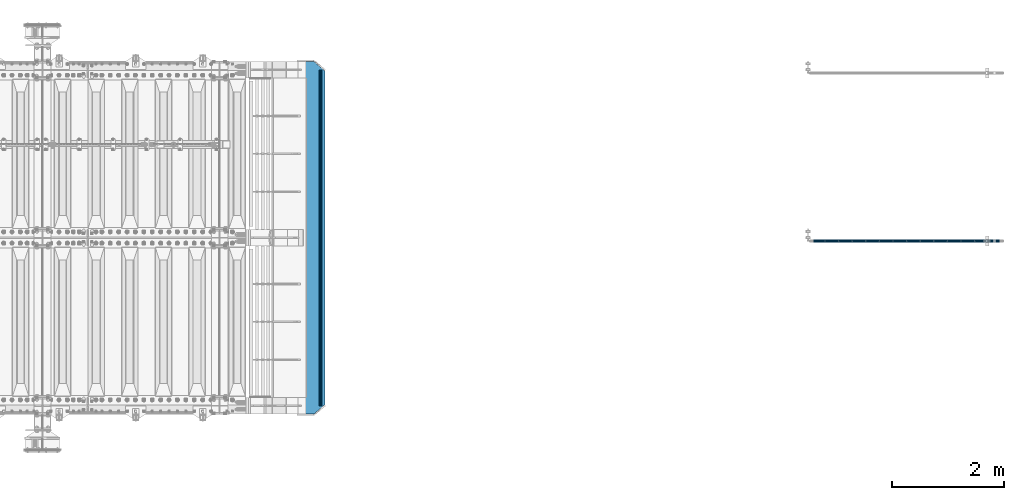
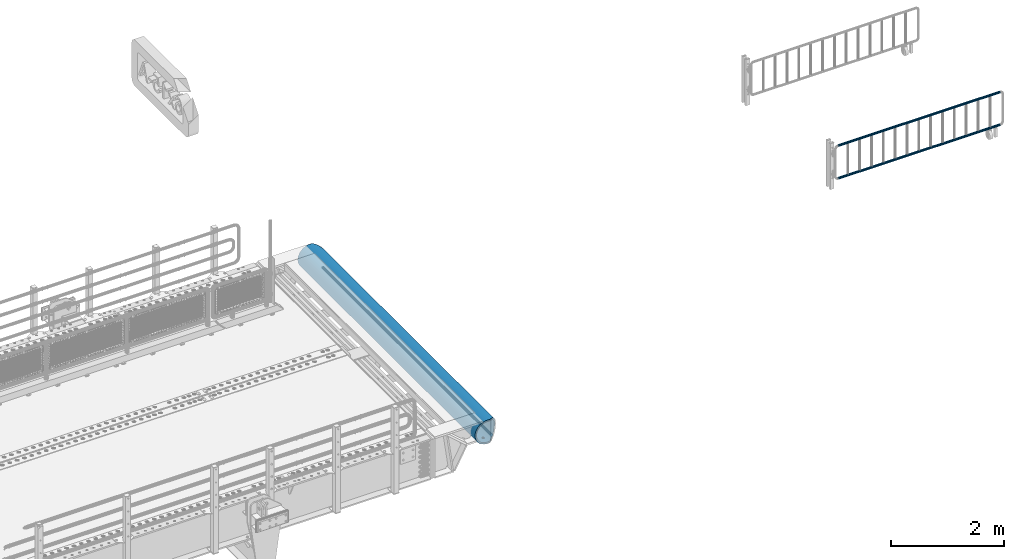
# One storey, part 103 of 193: 4 beams.
"""IFC2X3 building model written with IfcOpenShell, lengths in millimetres."""

from ifc_helpers import new_model, si_unit, frame, origin_with_axes, place, context, subcontext, project, spatial, faceted_brep, material, type_object, element, save


model = new_model("IFC2X3")

# Units and contexts
model_context = context("Model", 3, precision=1e-05, world=origin_with_axes())
body_context = subcontext(model_context, "Body", "Model", "MODEL_VIEW")
ifc_project = project(units=[si_unit("LENGTHUNIT", "METRE", prefix="MILLI"), si_unit("AREAUNIT", "SQUARE_METRE"), si_unit("VOLUMEUNIT", "CUBIC_METRE"), si_unit("MASSUNIT", "GRAM", prefix="KILO"), si_unit("TIMEUNIT", "SECOND"), si_unit("PLANEANGLEUNIT", "RADIAN"), si_unit("SOLIDANGLEUNIT", "STERADIAN"), si_unit("THERMODYNAMICTEMPERATUREUNIT", "DEGREE_CELSIUS"), si_unit("LUMINOUSINTENSITYUNIT", "LUMEN")], contexts=[model_context])

# Site, building, storey
site_placement = place(None, origin_with_axes())
site = spatial("IfcSite", under=ifc_project, at=site_placement, CompositionType="ELEMENT")
building_placement = place(site_placement, origin_with_axes())
building = spatial("IfcBuilding", under=site, at=building_placement, Name="Standard", CompositionType="ELEMENT")
storey_placement = place(building_placement, origin_with_axes())
storey = spatial("IfcBuildingStorey", under=building, at=storey_placement, Name="Undefined", CompositionType="ELEMENT", Elevation=0.0)

# Beams
ifc_material_1 = material()
beam_type_1 = type_object("IfcBeamType", PredefinedType="NOTDEFINED")
beam_1_placement = place(storey_placement, frame((-18284.7539827644, 26941.8539999962, 935.350006544462), z_axis=(0.0, 0.0, 1.0), x_axis=(1.0, 0.0, 0.0)))
element("IfcBeam", 1, at=beam_1_placement, inside=storey, type_object=beam_type_1, material=ifc_material_1, context=body_context, shape_type="Brep", body=[
    faceted_brep([(0.0, -20.5499999999993, 0.0), (0.0, -17.7968220477705, 10.2750000000015), (3317.7, -17.7968220477705, 10.275), (3317.7, -20.5499999999993, 0.0), (0.0, -10.2750000000015, 17.7968220477705), (3317.7, -10.2750000000015, 17.7968220477702), (0.0, 0.0, 20.5499999999993), (3317.7, 0.0, 20.55), (0.0, 10.2750000000015, 17.7968220477705), (3317.7, 10.2750000000015, 17.7968220477702), (0.0, 17.7968220477705, 10.2750000000015), (3317.7, 17.7968220477705, 10.275), (0.0, 20.5499999999993, 0.0), (3317.7, 20.5499999999993, 0.0), (0.0, 17.7968220477705, -10.2750000000015), (3317.7, 17.7968220477705, -10.275), (0.0, 10.2750000000015, -17.7968220477705), (3317.7, 10.2750000000015, -17.7968220477702), (0.0, 0.0, -20.5499999999993), (3317.7, 0.0, -20.55), (0.0, -10.2750000000015, -17.7968220477705), (3317.7, -10.2750000000015, -17.7968220477702), (0.0, -17.7968220477705, -10.2750000000015), (3317.7, -17.7968220477705, -10.275), (0.0, -24.1500000000015, 0.0), (0.0, -20.9145135013932, -12.0750000000007), (3317.7, -20.9145135013932, -12.075), (3317.7, -24.1500000000015, 0.0), (0.0, -12.0750000000007, -20.9145135013932), (3317.7, -12.0750000000007, -20.9145135013943), (0.0, 0.0, -24.1500000000015), (3317.7, 0.0, -24.15), (0.0, 12.0750000000007, -20.9145135013932), (3317.7, 12.0750000000007, -20.9145135013941), (0.0, 20.9145135013932, -12.0750000000007), (3317.7, 20.9145135013932, -12.075), (0.0, 24.1500000000015, 0.0), (3317.7, 24.1500000000015, 0.0), (0.0, 20.9145135013932, 12.0750000000007), (3317.7, 20.9145135013932, 12.075), (0.0, 12.0750000000007, 20.9145135013932), (3317.7, 12.0750000000007, 20.9145135013941), (0.0, 0.0, 24.1500000000015), (3317.7, 0.0, 24.15), (0.0, -12.0750000000007, 20.9145135013932), (3317.7, -12.0750000000007, 20.9145135013941), (0.0, -20.9145135013932, 12.0750000000007), (3317.7, -20.9145135013932, 12.075)], [[[0, 1, 2, 3]], [[1, 4, 5, 2]], [[4, 6, 7, 5]], [[6, 8, 9, 7]], [[8, 10, 11, 9]], [[10, 12, 13, 11]], [[12, 14, 15, 13]], [[14, 16, 17, 15]], [[16, 18, 19, 17]], [[18, 20, 21, 19]], [[20, 22, 23, 21]], [[22, 0, 3, 23]], [[24, 25, 26, 27]], [[25, 28, 29, 26]], [[28, 30, 31, 29]], [[30, 32, 33, 31]], [[32, 34, 35, 33]], [[34, 36, 37, 35]], [[36, 38, 39, 37]], [[38, 40, 41, 39]], [[40, 42, 43, 41]], [[42, 44, 45, 43]], [[44, 46, 47, 45]], [[46, 24, 27, 47]], [[29, 31, 33, 35, 37, 39, 41, 43, 45, 47, 27, 26], [5, 7, 9, 11, 13, 15, 17, 19, 21, 23, 3, 2]], [[46, 44, 42, 40, 38, 36, 34, 32, 30, 28, 25, 24], [22, 20, 18, 16, 14, 12, 10, 8, 6, 4, 1, 0]]]),
])
beam_2_placement = place(storey_placement, frame((-18284.7539827644, 26941.8539999962, 224.650006544463), z_axis=(0.0, 0.0, 1.0), x_axis=(1.0, 0.0, 0.0)))
element("IfcBeam", 2, at=beam_2_placement, inside=storey, type_object=beam_type_1, material=ifc_material_1, context=body_context, shape_type="Brep", body=[
    faceted_brep([(0.0, -20.5499999999993, 0.0), (0.0, -17.7968220477705, 10.2750000000015), (3317.7, -17.7968220477705, 10.275), (3317.7, -20.5499999999993, 0.0), (0.0, -10.2750000000015, 17.7968220477705), (3317.7, -10.2750000000015, 17.7968220477702), (0.0, 0.0, 20.5499999999993), (3317.7, 0.0, 20.55), (0.0, 10.2750000000015, 17.7968220477705), (3317.7, 10.2750000000015, 17.7968220477702), (0.0, 17.7968220477705, 10.2750000000015), (3317.7, 17.7968220477705, 10.275), (0.0, 20.5499999999993, 0.0), (3317.7, 20.5499999999993, 0.0), (0.0, 17.7968220477705, -10.2750000000015), (3317.7, 17.7968220477705, -10.275), (0.0, 10.2750000000015, -17.7968220477705), (3317.7, 10.2750000000015, -17.7968220477702), (0.0, 0.0, -20.5499999999993), (3317.7, 0.0, -20.55), (0.0, -10.2750000000015, -17.7968220477705), (3317.7, -10.2750000000015, -17.7968220477702), (0.0, -17.7968220477705, -10.2750000000015), (3317.7, -17.7968220477705, -10.275), (0.0, -24.1500000000015, 0.0), (0.0, -20.9145135013932, -12.0750000000007), (3317.7, -20.9145135013932, -12.075), (3317.7, -24.1500000000015, 0.0), (0.0, -12.0750000000007, -20.9145135013932), (3317.7, -12.0750000000007, -20.9145135013943), (0.0, 0.0, -24.1500000000015), (3317.7, 0.0, -24.15), (0.0, 12.0750000000007, -20.9145135013932), (3317.7, 12.0750000000007, -20.9145135013941), (0.0, 20.9145135013932, -12.0750000000007), (3317.7, 20.9145135013932, -12.075), (0.0, 24.1500000000015, 0.0), (3317.7, 24.1500000000015, 0.0), (0.0, 20.9145135013932, 12.0750000000007), (3317.7, 20.9145135013932, 12.075), (0.0, 12.0750000000007, 20.9145135013932), (3317.7, 12.0750000000007, 20.9145135013941), (0.0, 0.0, 24.1500000000015), (3317.7, 0.0, 24.15), (0.0, -12.0750000000007, 20.9145135013932), (3317.7, -12.0750000000007, 20.9145135013941), (0.0, -20.9145135013932, 12.0750000000007), (3317.7, -20.9145135013932, 12.075)], [[[0, 1, 2, 3]], [[1, 4, 5, 2]], [[4, 6, 7, 5]], [[6, 8, 9, 7]], [[8, 10, 11, 9]], [[10, 12, 13, 11]], [[12, 14, 15, 13]], [[14, 16, 17, 15]], [[16, 18, 19, 17]], [[18, 20, 21, 19]], [[20, 22, 23, 21]], [[22, 0, 3, 23]], [[24, 25, 26, 27]], [[25, 28, 29, 26]], [[28, 30, 31, 29]], [[30, 32, 33, 31]], [[32, 34, 35, 33]], [[34, 36, 37, 35]], [[36, 38, 39, 37]], [[38, 40, 41, 39]], [[40, 42, 43, 41]], [[42, 44, 45, 43]], [[44, 46, 47, 45]], [[46, 24, 27, 47]], [[29, 31, 33, 35, 37, 39, 41, 43, 45, 47, 27, 26], [5, 7, 9, 11, 13, 15, 17, 19, 21, 23, 3, 2]], [[46, 44, 42, 40, 38, 36, 34, 32, 30, 28, 25, 24], [22, 20, 18, 16, 14, 12, 10, 8, 6, 4, 1, 0]]]),
])
ifc_material_2 = material(Name="STEEL/S355N")
beam_type_2 = type_object("IfcBeamType", Name="D60", PredefinedType="NOTDEFINED")
beam_3_placement = place(storey_placement, frame((-27093.2474739935, 24000.0, -478.0), z_axis=(0.0, 0.0, 1.0), x_axis=(0.0, 1.0, 0.0)))
element("IfcBeam", 3, at=beam_3_placement, inside=storey, type_object=beam_type_2, material=ifc_material_2, ObjectType="D60", context=body_context, shape_type="Brep", body=[
    faceted_brep([(0.0, -29.9999999999964, 0.0), (0.0, -27.7163859753382, -11.4805029709527), (6000.00000000114, -27.7163859753382, -11.4805029709527), (6000.00000000114, -29.9999999999964, 0.0), (0.0, -21.2132034355964, -21.2132034355964), (6000.00000000114, -21.2132034355964, -21.2132034355964), (0.0, -11.4805029709496, -27.7163859753386), (6000.00000000114, -11.4805029709496, -27.7163859753386), (0.0, 0.0, -30.0), (6000.00000000114, 0.0, -30.0), (0.0, 11.4805029709532, -27.7163859753386), (6000.00000000114, 11.4805029709532, -27.7163859753386), (0.0, 21.2132034355964, -21.2132034355964), (6000.00000000114, 21.2132034355964, -21.2132034355964), (0.0, 27.7163859753418, -11.4805029709527), (6000.00000000114, 27.7163859753418, -11.4805029709527), (0.0, 30.0, 0.0), (6000.00000000114, 30.0, 0.0), (0.0, 27.7163859753418, 11.4805029709527), (6000.00000000114, 27.7163859753418, 11.4805029709527), (0.0, 21.2132034355964, 21.2132034355964), (6000.00000000114, 21.2132034355964, 21.2132034355964), (0.0, 11.4805029709532, 27.7163859753386), (6000.00000000114, 11.4805029709532, 27.7163859753386), (0.0, 0.0, 30.0), (6000.00000000114, 0.0, 30.0), (0.0, -11.4805029709496, 27.7163859753386), (6000.00000000114, -11.4805029709496, 27.7163859753386), (0.0, -21.2132034355964, 21.2132034355964), (6000.00000000114, -21.2132034355964, 21.2132034355964), (0.0, -27.7163859753382, 11.4805029709527), (6000.00000000114, -27.7163859753382, 11.4805029709527)], [[[0, 1, 2, 3]], [[1, 4, 5, 2]], [[4, 6, 7, 5]], [[6, 8, 9, 7]], [[8, 10, 11, 9]], [[10, 12, 13, 11]], [[12, 14, 15, 13]], [[14, 16, 17, 15]], [[16, 18, 19, 17]], [[18, 20, 21, 19]], [[20, 22, 23, 21]], [[22, 24, 25, 23]], [[24, 26, 27, 25]], [[26, 28, 29, 27]], [[28, 30, 31, 29]], [[30, 0, 3, 31]], [[5, 7, 9, 11, 13, 15, 17, 19, 21, 23, 25, 27, 29, 31, 3, 2]], [[30, 28, 26, 24, 22, 20, 18, 16, 14, 12, 10, 8, 6, 4, 1, 0]]]),
])
beam_type_3 = type_object("IfcBeamType", PredefinedType="NOTDEFINED")
beam_4_placement = place(storey_placement, frame((-27267.0011701094, 30150.0, -254.000000000001), z_axis=(0.0, 0.0, 1.0), x_axis=(0.0, -1.0, 0.0)))
element("IfcBeam", 4, at=beam_4_placement, inside=storey, type_object=beam_type_3, material=ifc_material_2, context=body_context, shape_type="Brep", body=[
    faceted_brep([(4659.56708580913, 23.1006844286749, -220.181936706647), (4659.56708580913, 23.1006844286749, -252.181936706646), (4667.67766952966, 17.6813656455561, -252.608446344704), (4667.67766952966, 17.6813656455561, -220.608446344705), (4673.09698831278, 9.57078192502013, -253.246763126855), (4673.09698831278, 9.57078192502013, -221.246763126855), (4675.0, 0.0, -254.0), (4675.0, 0.0, -222.0), (4673.09698831278, -9.5633896932377, -253.247344908113), (4673.09698831278, -9.5633896932377, -221.247344908113), (4667.67766952966, -17.6739734137736, -252.609028125963), (4667.67766952966, -17.6739734137736, -220.609028125963), (4659.56708580913, -23.0932921968924, -252.182518487905), (4659.56708580913, -23.0932921968924, -220.182518487905), (4650.0, -24.9963038841088, -252.032748220013), (4650.0, -24.9963038841088, -220.032748220014), (4640.43291419087, -23.0932921968924, -252.182518487905), (4640.43291419087, -23.0932921968924, -220.182518487905), (4632.32233047034, -17.6739734137736, -252.609028125963), (4632.32233047034, -17.6739734137736, -220.609028125963), (4626.90301168722, -9.5633896932377, -253.247344908113), (4626.90301168722, -9.5633896932377, -221.247344908113), (4625.0, 0.0, -254.0), (4625.0, 0.0, -222.0), (4626.90301168722, 9.57078192502013, -253.246763126855), (4626.90301168722, 9.57078192502013, -221.246763126855), (4632.32233047034, 17.6813656455561, -252.608446344704), (4632.32233047034, 17.6813656455561, -220.608446344705), (4640.43291419087, 23.1006844286749, -252.181936706646), (4640.43291419087, 23.1006844286749, -220.181936706647), (4650.0, 25.0036961158912, -252.032166438755), (4650.0, 25.0036961158912, -220.032166438756), (1632.32233047034, -17.6776695296612, -220.608737235334), (1632.32233047034, -17.6776695296612, -252.608737235334), (1626.90301168722, -9.56708580912527, -253.247054017484), (1626.90301168722, -9.56708580912527, -221.247054017484), (1640.43291419087, -23.09698831278, -220.182227597276), (1640.43291419087, -23.09698831278, -252.182227597276), (1650.0, -24.9999999999964, -220.032457329384), (1650.0, -24.9999999999964, -252.032457329385), (1659.56708580913, -23.09698831278, -220.182227597276), (1659.56708580913, -23.09698831278, -252.182227597276), (1667.67766952966, -17.6776695296612, -220.608737235334), (1667.67766952966, -17.6776695296612, -252.608737235334), (1673.09698831278, -9.56708580912527, -221.247054017484), (1673.09698831278, -9.56708580912527, -253.247054017484), (1675.0, 0.0, -222.0), (1675.0, 0.0, -254.0), (1673.09698831278, 9.56708580913255, -221.247054017483), (1673.09698831278, 9.56708580913255, -253.247054017484), (1667.67766952966, 17.6776695296685, -220.608737235333), (1667.67766952966, 17.6776695296685, -252.608737235334), (1659.56708580913, 23.0969883127873, -220.182227597275), (1659.56708580913, 23.0969883127873, -252.182227597275), (1650.0, 25.0000000000036, -220.032457329384), (1650.0, 25.0000000000036, -252.032457329384), (1640.43291419087, 23.0969883127873, -220.182227597275), (1640.43291419087, 23.0969883127873, -252.182227597275), (1632.32233047034, 17.6776695296685, -220.608737235333), (1632.32233047034, 17.6776695296685, -252.608737235334), (1626.90301168722, 9.56708580913255, -221.247054017483), (1626.90301168722, 9.56708580913255, -253.247054017484), (1625.0, 0.0, -222.0), (1625.0, 0.0, -254.0), (132.322330470335, -17.6776695296612, -220.608737235334), (132.322330470335, -17.6776695296612, -252.608737235334), (126.903011687216, -9.56708580912527, -253.247054017484), (126.903011687216, -9.56708580912527, -221.247054017484), (140.432914190871, -23.09698831278, -220.182227597276), (140.432914190871, -23.09698831278, -252.182227597276), (150.0, -24.9999999999964, -220.032457329385), (150.0, -24.9999999999964, -252.032457329385), (159.567085809129, -23.09698831278, -220.182227597276), (159.567085809129, -23.09698831278, -252.182227597276), (167.677669529665, -17.6776695296612, -220.608737235334), (167.677669529665, -17.6776695296612, -252.608737235334), (173.096988312784, -9.56708580912527, -221.247054017484), (173.096988312784, -9.56708580912527, -253.247054017484), (175.0, 0.0, -222.0), (175.0, 0.0, -254.0), (173.096988312784, 9.56708580913255, -221.247054017483), (173.096988312784, 9.56708580913255, -253.247054017484), (167.677669529665, 17.6776695296685, -220.608737235333), (167.677669529665, 17.6776695296685, -252.608737235334), (159.567085809129, 23.0969883127873, -220.182227597275), (159.567085809129, 23.0969883127873, -252.182227597275), (150.0, 25.0000000000036, -220.032457329384), (150.0, 25.0000000000036, -252.032457329384), (140.432914190871, 23.0969883127873, -220.182227597275), (140.432914190871, 23.0969883127873, -252.182227597275), (132.322330470335, 17.6776695296685, -220.608737235333), (132.322330470335, 17.6776695296685, -252.608737235334), (126.903011687216, 9.56708580913255, -221.247054017483), (126.903011687216, 9.56708580913255, -253.247054017484), (125.0, 0.0, -222.0), (125.0, 0.0, -254.0), (0.0, -34.7284512389306, -219.266811612121), (0.0, -68.6017727512371, -211.134546617524), (6300.0, -68.6017727512371, -211.134546617524), (6300.0, -34.7284512389306, -219.266811612121), (0.0, -100.785890942181, -197.803448369818), (6300.0, -100.785890942181, -197.803448369818), (0.0, -130.48832600893, -179.601772751238), (6300.0, -130.48832600893, -179.601772751238), (0.0, -156.977705423415, -156.977705423414), (6300.0, -156.977705423415, -156.977705423414), (0.0, -179.601772751237, -130.488326008929), (6300.0, -179.601772751237, -130.488326008929), (0.0, -197.803448369817, -100.785890942179), (6300.0, -197.803448369817, -100.785890942179), (0.0, -211.134546617523, -68.6017727512383), (6300.0, -211.134546617523, -68.6017727512383), (0.0, -219.26681161212, -34.7284512389313), (6300.0, -219.26681161212, -34.7284512389313), (0.0, -222.0, 0.0), (6300.0, -222.0, 0.0), (0.0, -219.26681161212, 34.7284512389313), (6300.0, -219.26681161212, 34.7284512389313), (0.0, -211.134546617523, 68.6017727512384), (6300.0, -211.134546617523, 68.6017727512384), (0.0, -197.803448369817, 100.785890942179), (6300.0, -197.803448369817, 100.785890942179), (0.0, -179.601772751237, 130.488326008929), (6300.0, -179.601772751237, 130.488326008929), (0.0, -156.977705423415, 156.977705423414), (6300.0, -156.977705423415, 156.977705423414), (0.0, -130.48832600893, 179.601772751238), (6300.0, -130.48832600893, 179.601772751238), (0.0, -100.785890942181, 197.803448369818), (6300.0, -100.785890942181, 197.803448369818), (0.0, -68.6017727512371, 211.134546617524), (6300.0, -68.6017727512371, 211.134546617524), (0.0, -34.7284512389306, 219.266811612121), (6300.0, -34.7284512389306, 219.266811612121), (0.0, 0.0, 222.0), (6300.0, 0.0, 222.0), (0.0, 34.7284512389306, 219.266811612121), (6300.0, 34.7284512389306, 219.266811612121), (6287.59163509755, 68.6017727512371, 211.134546617524), (6300.0, 54.0036961158912, 214.639234741094), (0.0, 54.0000000000036, 214.64012210001), (12.4115067427229, 68.6017727512371, 211.134546617524), (6260.23513515906, 100.785890942181, 197.803448369818), (39.7680069938178, 100.785890942181, 197.803448369818), (6234.98806583575, 130.48832600893, 179.601772751238), (65.0150766056358, 130.48832600893, 179.601772751238), (6212.47209376457, 156.977705423415, 156.977705423414), (87.5310489341136, 156.977705423415, 156.977705423414), (6193.24163690413, 179.601772751237, 130.488326008929), (106.761506014293, 179.601772751237, 130.488326008929), (6177.77021292458, 197.803448369817, 100.785890942179), (122.232930170641, 197.803448369817, 100.785890942179), (6166.43877963101, 211.134546617523, 68.6017727512383), (133.564363593709, 211.134546617523, 68.6017727512383), (6159.52635451796, 219.26681161212, 34.7284512389312), (140.476788785749, 219.26681161212, 34.7284512389312), (6157.20314443275, 222.0, -2.8421709430404e-14), (142.799998897506, 222.0, -2.8421709430404e-14), (6159.52635451796, 219.26681161212, -34.7284512389313), (140.476788785749, 219.26681161212, -34.7284512389313), (6166.43877963101, 211.134546617523, -68.6017727512383), (133.564363593709, 211.134546617523, -68.6017727512383), (6177.77021292458, 197.803448369817, -100.785890942179), (122.232930170641, 197.803448369817, -100.785890942179), (6193.24163690413, 179.601772751237, -130.488326008929), (106.761506014293, 179.601772751237, -130.488326008929), (6212.47209376457, 156.977705423415, -156.977705423414), (87.5310489341136, 156.977705423415, -156.977705423414), (6234.98806583575, 130.48832600893, -179.601772751238), (65.0150766056358, 130.48832600893, -179.601772751238), (6260.23513515906, 100.785890942181, -197.803448369818), (39.7680069938178, 100.785890942181, -197.803448369818), (6287.59163509755, 68.6017727512371, -211.134546617524), (12.4115067427229, 68.6017727512371, -211.134546617524), (0.0, 34.7284512389306, -219.266811612121), (6300.0, 34.7284512389306, -219.266811612121), (6300.0, 54.0036961158912, -214.639234741094), (0.0, 54.0000000000036, -214.64012210001), (6140.5700428831, 241.56835513897, -78.4903165712366), (6153.53483593071, 226.315657143845, -115.313586933845), (146.468307441457, 226.315657143845, -115.313586933845), (159.433100637219, 241.56835513897, -78.4903165712366), (6171.23637507848, 205.490316571235, -149.297454082288), (128.766768091398, 205.490316571235, -149.297454082288), (6193.23878968456, 179.605122421384, -179.605122421383), (106.764353233899, 179.605122421384, -179.605122421383), (6219.00030727952, 149.297454082287, -205.490316571237), (81.0028353445559, 149.297454082287, -205.490316571237), (6247.8865938026, 115.313586933844, -226.315657143845), (52.1165484913945, 115.313586933844, -226.315657143845), (6279.1863730115, 78.4903165712349, -241.568355138969), (20.8167689248257, 78.4903165712349, -241.568355138969), (6300.0, 54.0036961158912, -247.447072591954), (6300.0, 39.7343541202172, -250.872838511165), (0.0, 39.7343541202172, -250.872838511165), (0.0, 54.0000000000036, -247.447959950869), (0.0, 0.0, -222.0), (0.0, 0.0, -254.0), (0.0, -39.7343541202172, -250.872838511165), (0.0, -78.4903165712349, -241.568355138969), (0.0, -115.313586933844, -226.315657143845), (0.0, -149.297454082287, -205.490316571237), (0.0, -179.605122421384, -179.605122421383), (0.0, -205.490316571235, -149.297454082288), (0.0, -226.315657143845, -115.313586933845), (0.0, -241.56835513897, -78.4903165712367), (0.0, -250.872838511164, -39.7343541202187), (0.0, -254.0, 0.0), (0.0, -250.872838511164, 39.7343541202187), (0.0, -241.56835513897, 78.4903165712366), (0.0, -226.315657143845, 115.313586933845), (0.0, -205.490316571235, 149.297454082288), (0.0, -179.605122421384, 179.605122421383), (0.0, -149.297454082287, 205.490316571237), (0.0, -115.313586933844, 226.315657143845), (0.0, -78.4903165712349, 241.568355138969), (0.0, -39.7343541202172, 250.872838511165), (0.0, 0.0, 254.0), (0.0, 39.7343541202172, 250.872838511165), (0.0, 54.0000000000036, 247.447959950869), (6300.0, -39.7343541202172, -250.872838511165), (6300.0, -78.4903165712349, -241.568355138969), (6300.0, -115.313586933844, -226.315657143845), (6300.0, -149.297454082287, -205.490316571237), (6300.0, -179.605122421384, -179.605122421383), (6300.0, -205.490316571235, -149.297454082288), (6300.0, -226.315657143845, -115.313586933845), (6300.0, -241.56835513897, -78.4903165712367), (6300.0, -250.872838511164, -39.7343541202187), (6300.0, -254.0, 0.0), (6300.0, -250.872838511164, 39.7343541202187), (6300.0, -241.56835513897, 78.4903165712366), (6300.0, -226.315657143845, 115.313586933845), (6300.0, -205.490316571235, 149.297454082288), (6300.0, -179.605122421384, 179.605122421383), (6300.0, -149.297454082287, 205.490316571237), (6300.0, -115.313586933844, 226.315657143845), (6300.0, -78.4903165712349, 241.568355138969), (6300.0, -39.7343541202172, 250.872838511165), (6300.0, 0.0, 254.0), (6300.0, 39.7343541202172, 250.872838511165), (6300.0, 54.0036961158912, 247.447072591954), (6279.1863730115, 78.4903165712349, 241.568355138969), (20.8167689248257, 78.4903165712349, 241.568355138969), (6247.8865938026, 115.313586933844, 226.315657143845), (52.1165484913945, 115.313586933844, 226.315657143845), (6219.00030727952, 149.297454082287, 205.490316571237), (81.0028353445559, 149.297454082287, 205.490316571237), (6193.23878968456, 179.605122421384, 179.605122421383), (106.764353233899, 179.605122421384, 179.605122421383), (6171.23637507848, 205.490316571235, 149.297454082288), (128.766768091398, 205.490316571235, 149.297454082288), (6153.53483593071, 226.315657143845, 115.313586933845), (146.468307441457, 226.315657143845, 115.313586933845), (6140.5700428831, 241.56835513897, 78.4903165712367), (159.433100637219, 241.56835513897, 78.4903165712367), (6129.99999983257, 254.00370014241, 0.0), (6132.66123216816, 250.872838511164, -39.7343541202186), (167.341911442523, 250.872838511164, -39.7343541202186), (170.000001295226, 254.000003067897, 5.6843418860808e-14), (6132.66123216816, 250.872838511164, 39.7343541202187), (167.341911442523, 250.872838511164, 39.7343541202187), (6300.0, 0.0, -254.0), (6300.0, 0.0, -222.0), (6132.32233047034, -17.6739734137809, -220.609028125963), (6132.32233047034, -17.6739734137809, -252.609028125963), (6126.90301168722, -9.56338969324497, -253.247344908113), (6126.90301168722, -9.56338969324497, -221.247344908113), (6140.43291419087, -23.0932921968997, -220.182518487905), (6140.43291419087, -23.0932921968997, -252.182518487904), (6150.0, -24.9963038841161, -220.032748220014), (6150.0, -24.9963038841161, -252.032748220013), (6159.56708580913, -23.0932921968997, -220.182518487905), (6159.56708580913, -23.0932921968997, -252.182518487904), (6167.67766952966, -17.6739734137809, -220.609028125963), (6167.67766952966, -17.6739734137809, -252.609028125963), (6173.09698831278, -9.56338969324497, -221.247344908113), (6173.09698831278, -9.56338969324497, -253.247344908113), (6175.0, 0.0, -222.0), (6175.0, 0.0, -254.0), (6173.09698831278, 9.57078192501285, -221.246763126855), (6173.09698831278, 9.57078192501285, -253.246763126855), (6167.67766952966, 17.6813656455488, -220.608446344705), (6167.67766952966, 17.6813656455488, -252.608446344706), (6159.56708580913, 23.1006844286676, -220.181936706647), (6159.56708580913, 23.1006844286676, -252.181936706647), (6150.0, 25.0036961158839, -220.032166438755), (6150.0, 25.0036961158839, -252.032166438756), (6140.43291419087, 23.1006844286676, -220.181936706647), (6140.43291419087, 23.1006844286676, -252.181936706647), (6132.32233047034, 17.6813656455488, -220.608446344705), (6132.32233047034, 17.6813656455488, -252.608446344706), (6126.90301168722, 9.57078192501285, -221.246763126855), (6126.90301168722, 9.57078192501285, -253.246763126855), (6125.0, 0.0, -222.0), (6125.0, 0.0, -254.0), (3175.0, 0.0, -222.0), (3173.09698831278, -9.56708580912527, -221.247054017484), (3167.67766952966, -17.6776695296612, -220.608737235334), (3159.56708580913, -23.09698831278, -220.182227597276), (3150.0, -24.9999999999964, -220.032457329385), (3140.43291419087, -23.09698831278, -220.182227597276), (3132.32233047034, -17.6776695296612, -220.608737235334), (3126.90301168722, -9.56708580912527, -221.247054017484), (3125.0, 0.0, -222.0), (3126.90301168722, 9.56708580913255, -221.247054017483), (3132.32233047034, 17.6776695296685, -220.608737235333), (3140.43291419087, 23.0969883127873, -220.182227597275), (3150.0, 25.0000000000036, -220.032457329384), (3159.56708580913, 23.0969883127873, -220.182227597275), (3167.67766952966, 17.6776695296685, -220.608737235333), (3173.09698831278, 9.56708580913255, -221.247054017483), (3173.09698831278, 9.56708580913255, -253.247054017484), (3175.0, 0.0, -254.0), (3167.67766952966, 17.6776695296685, -252.608737235334), (3159.56708580913, 23.0969883127873, -252.182227597276), (3150.0, 25.0000000000036, -252.032457329385), (3140.43291419087, 23.0969883127873, -252.182227597276), (3132.32233047034, 17.6776695296685, -252.608737235334), (3126.90301168722, 9.56708580913255, -253.247054017484), (3125.0, 0.0, -254.0), (3126.90301168722, -9.56708580912527, -253.247054017484), (3132.32233047034, -17.6776695296612, -252.608737235334), (3140.43291419087, -23.09698831278, -252.182227597276), (3150.0, -24.9999999999964, -252.032457329385), (3159.56708580913, -23.09698831278, -252.182227597276), (3167.67766952966, -17.6776695296612, -252.608737235334), (3173.09698831278, -9.56708580912527, -253.247054017484)], [[[0, 1, 2, 3]], [[3, 2, 4, 5]], [[5, 4, 6, 7]], [[7, 6, 8, 9]], [[9, 8, 10, 11]], [[11, 10, 12, 13]], [[13, 12, 14, 15]], [[15, 14, 16, 17]], [[17, 16, 18, 19]], [[19, 18, 20, 21]], [[21, 20, 22, 23]], [[23, 22, 24, 25]], [[25, 24, 26, 27]], [[27, 26, 28, 29]], [[29, 28, 30, 31]], [[31, 30, 1, 0]], [[32, 33, 34, 35]], [[36, 37, 33, 32]], [[38, 39, 37, 36]], [[40, 41, 39, 38]], [[42, 43, 41, 40]], [[44, 45, 43, 42]], [[46, 47, 45, 44]], [[48, 49, 47, 46]], [[50, 51, 49, 48]], [[52, 53, 51, 50]], [[54, 55, 53, 52]], [[56, 57, 55, 54]], [[58, 59, 57, 56]], [[60, 61, 59, 58]], [[62, 63, 61, 60]], [[35, 34, 63, 62]], [[64, 65, 66, 67]], [[68, 69, 65, 64]], [[70, 71, 69, 68]], [[72, 73, 71, 70]], [[74, 75, 73, 72]], [[76, 77, 75, 74]], [[78, 79, 77, 76]], [[80, 81, 79, 78]], [[82, 83, 81, 80]], [[84, 85, 83, 82]], [[86, 87, 85, 84]], [[88, 89, 87, 86]], [[90, 91, 89, 88]], [[92, 93, 91, 90]], [[94, 95, 93, 92]], [[67, 66, 95, 94]], [[96, 97, 98, 99]], [[97, 100, 101, 98]], [[100, 102, 103, 101]], [[102, 104, 105, 103]], [[104, 106, 107, 105]], [[106, 108, 109, 107]], [[108, 110, 111, 109]], [[110, 112, 113, 111]], [[112, 114, 115, 113]], [[114, 116, 117, 115]], [[116, 118, 119, 117]], [[118, 120, 121, 119]], [[120, 122, 123, 121]], [[122, 124, 125, 123]], [[124, 126, 127, 125]], [[126, 128, 129, 127]], [[128, 130, 131, 129]], [[130, 132, 133, 131]], [[132, 134, 135, 133]], [[134, 136, 137, 135]], [[138, 139, 137, 136, 140, 141]], [[142, 138, 141, 143]], [[144, 142, 143, 145]], [[146, 144, 145, 147]], [[148, 146, 147, 149]], [[150, 148, 149, 151]], [[152, 150, 151, 153]], [[154, 152, 153, 155]], [[156, 154, 155, 157]], [[158, 156, 157, 159]], [[160, 158, 159, 161]], [[162, 160, 161, 163]], [[164, 162, 163, 165]], [[166, 164, 165, 167]], [[168, 166, 167, 169]], [[170, 168, 169, 171]], [[172, 170, 171, 173]], [[174, 175, 176, 172, 173, 177]], [[178, 179, 180, 181]], [[179, 182, 183, 180]], [[182, 184, 185, 183]], [[184, 186, 187, 185]], [[186, 188, 189, 187]], [[188, 190, 191, 189]], [[190, 192, 193, 194, 195, 191]], [[136, 134, 132, 130, 128, 126, 124, 122, 120, 118, 116, 114, 112, 110, 108, 106, 104, 102, 100, 97, 96, 196, 174, 177, 195, 194, 197, 198, 199, 200, 201, 202, 203, 204, 205, 206, 207, 208, 209, 210, 211, 212, 213, 214, 215, 216, 217, 218, 219, 140]], [[199, 198, 220, 221]], [[200, 199, 221, 222]], [[201, 200, 222, 223]], [[202, 201, 223, 224]], [[203, 202, 224, 225]], [[204, 203, 225, 226]], [[205, 204, 226, 227]], [[206, 205, 227, 228]], [[207, 206, 228, 229]], [[208, 207, 229, 230]], [[209, 208, 230, 231]], [[210, 209, 231, 232]], [[211, 210, 232, 233]], [[212, 211, 233, 234]], [[213, 212, 234, 235]], [[214, 213, 235, 236]], [[215, 214, 236, 237]], [[216, 215, 237, 238]], [[217, 216, 238, 239]], [[218, 217, 239, 240]], [[218, 240, 241, 242, 243, 219]], [[242, 244, 245, 243]], [[244, 246, 247, 245]], [[246, 248, 249, 247]], [[248, 250, 251, 249]], [[250, 252, 253, 251]], [[252, 254, 255, 253]], [[256, 257, 258, 259]], [[260, 256, 259, 261]], [[254, 260, 261, 255]], [[259, 258, 181, 180, 183, 185, 187, 189, 191, 195, 177, 173, 171, 169, 167, 165, 163, 161, 159, 157, 155, 153, 151, 149, 147, 145, 143, 141, 140, 219, 243, 245, 247, 249, 251, 253, 255, 261]], [[257, 178, 181, 258]], [[256, 260, 254, 252, 250, 248, 246, 244, 242, 241, 139, 138, 142, 144, 146, 148, 150, 152, 154, 156, 158, 160, 162, 164, 166, 168, 170, 172, 176, 192, 190, 188, 186, 184, 182, 179, 178, 257]], [[240, 239, 238, 237, 236, 235, 234, 233, 232, 231, 230, 229, 228, 227, 226, 225, 224, 223, 222, 221, 220, 262, 193, 192, 176, 175, 263, 99, 98, 101, 103, 105, 107, 109, 111, 113, 115, 117, 119, 121, 123, 125, 127, 129, 131, 133, 135, 137, 139, 241]], [[264, 265, 266, 267]], [[268, 269, 265, 264]], [[270, 271, 269, 268]], [[272, 273, 271, 270]], [[274, 275, 273, 272]], [[276, 277, 275, 274]], [[278, 279, 277, 276]], [[280, 281, 279, 278]], [[282, 283, 281, 280]], [[284, 285, 283, 282]], [[286, 287, 285, 284]], [[288, 289, 287, 286]], [[290, 291, 289, 288]], [[292, 293, 291, 290]], [[294, 295, 293, 292]], [[267, 266, 295, 294]], [[296, 297, 298, 299, 300, 301, 302, 303, 304, 46, 44, 42, 40, 38, 36, 32, 35, 62, 78, 76, 74, 72, 70, 68, 64, 67, 94, 196, 96, 99, 263, 278, 276, 274, 272, 270, 268, 264, 267, 294, 7, 9, 11, 13, 15, 17, 19, 21, 23]], [[3, 5, 7, 294, 292, 290, 288, 286, 284, 282, 280, 278, 263, 175, 174, 196, 94, 92, 90, 88, 86, 84, 82, 80, 78, 62, 60, 58, 56, 54, 52, 50, 48, 46, 304, 305, 306, 307, 308, 309, 310, 311, 296, 23, 25, 27, 29, 31, 0]], [[311, 312, 313, 296]], [[310, 314, 312, 311]], [[309, 315, 314, 310]], [[308, 316, 315, 309]], [[307, 317, 316, 308]], [[306, 318, 317, 307]], [[305, 319, 318, 306]], [[304, 320, 319, 305]], [[303, 321, 320, 304]], [[302, 322, 321, 303]], [[301, 323, 322, 302]], [[300, 324, 323, 301]], [[299, 325, 324, 300]], [[298, 326, 325, 299]], [[297, 327, 326, 298]], [[296, 313, 327, 297]], [[18, 16, 14, 12, 10, 8, 6, 295, 266, 265, 269, 271, 273, 275, 277, 279, 262, 220, 198, 197, 95, 66, 65, 69, 71, 73, 75, 77, 79, 63, 34, 33, 37, 39, 41, 43, 45, 47, 320, 321, 322, 323, 324, 325, 326, 327, 313, 22, 20]], [[26, 24, 22, 313, 312, 314, 315, 316, 317, 318, 319, 320, 47, 49, 51, 53, 55, 57, 59, 61, 63, 79, 81, 83, 85, 87, 89, 91, 93, 95, 197, 194, 193, 262, 279, 281, 283, 285, 287, 289, 291, 293, 295, 6, 4, 2, 1, 30, 28]]]),
])

save(model, "model.ifc")
